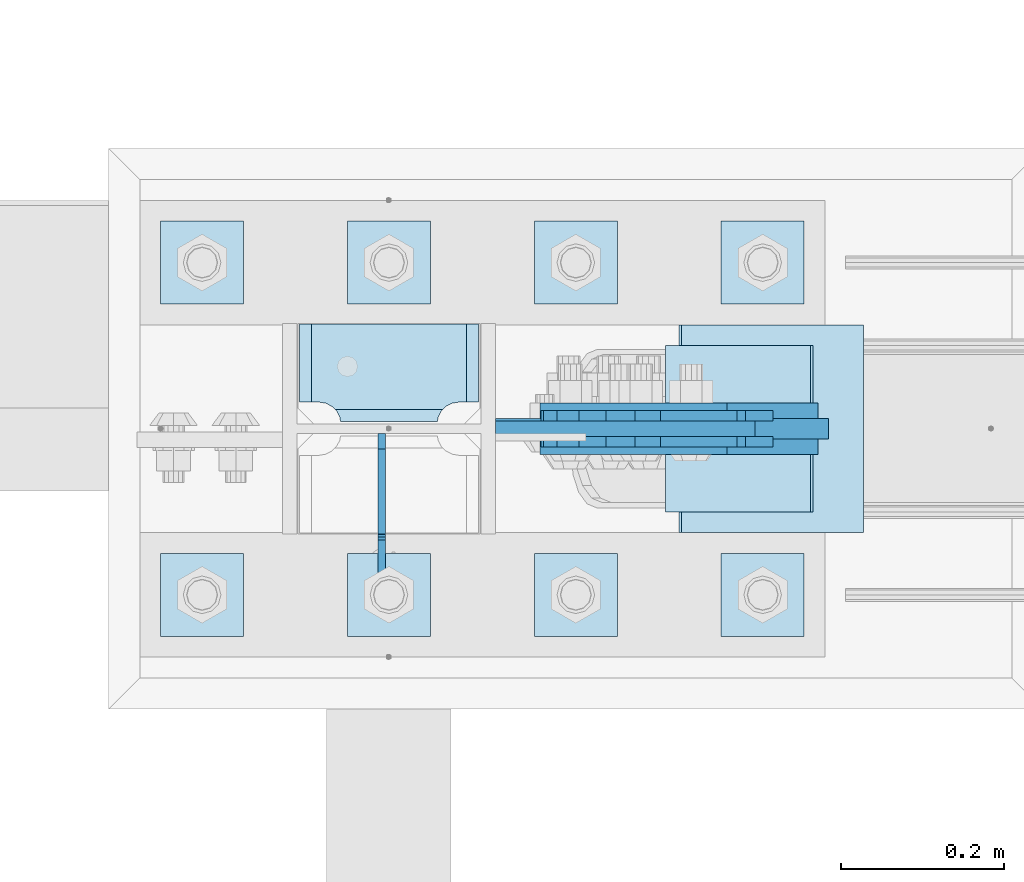
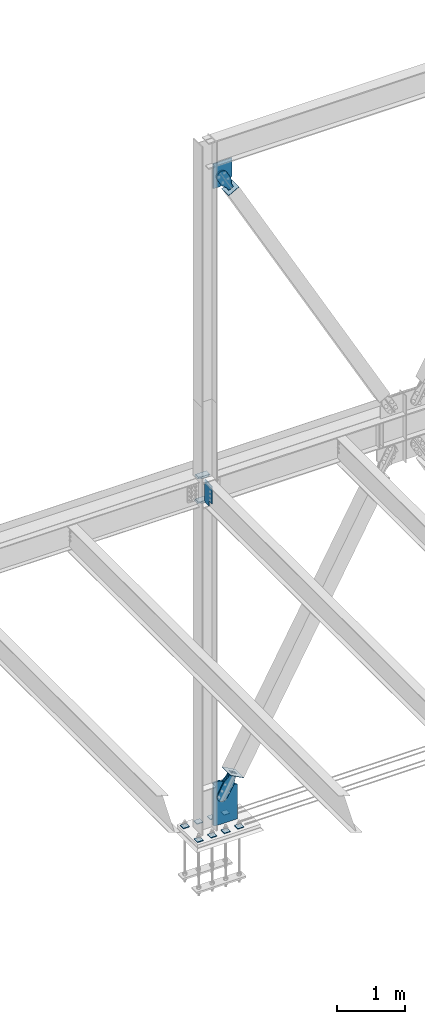
# One storey, part 3527 of 3843: 19 plates, 9 elements without a shape of their own.
"""IFC2X3 building model written with IfcOpenShell, lengths in millimetres."""

from ifc_helpers import new_model, si_unit, frame, origin_with_axes, place, context, subcontext, project, spatial, faceted_brep, material, type_object, element, aggregate, save


model = new_model("IFC2X3")

# Units and contexts
model_context = context("Model", 3, precision=1e-05, world=origin_with_axes())
body_context = subcontext(model_context, "Body", "Model", "MODEL_VIEW")
ifc_project = project(units=[si_unit("LENGTHUNIT", "METRE", prefix="MILLI"), si_unit("AREAUNIT", "SQUARE_METRE"), si_unit("VOLUMEUNIT", "CUBIC_METRE"), si_unit("MASSUNIT", "GRAM", prefix="KILO"), si_unit("TIMEUNIT", "SECOND"), si_unit("PLANEANGLEUNIT", "RADIAN"), si_unit("SOLIDANGLEUNIT", "STERADIAN"), si_unit("THERMODYNAMICTEMPERATUREUNIT", "DEGREE_CELSIUS"), si_unit("LUMINOUSINTENSITYUNIT", "LUMEN")], contexts=[model_context])

# Site, building, storey
site_placement = place(None, origin_with_axes())
site = spatial("IfcSite", under=ifc_project, at=site_placement, CompositionType="ELEMENT")
building_placement = place(site_placement, origin_with_axes())
building = spatial("IfcBuilding", under=site, at=building_placement, Name="Undefined", CompositionType="ELEMENT")
storey_placement = place(building_placement, origin_with_axes())
storey = spatial("IfcBuildingStorey", under=building, at=storey_placement, Name="Undefined", CompositionType="ELEMENT", Elevation=0.0)

# Assembly, plates
assembly_1_placement = place(storey_placement, origin_with_axes())
assembly_1 = element("IfcElementAssembly", 1, at=assembly_1_placement, inside=storey, Name="COLUMN", AssemblyPlace="NOTDEFINED", PredefinedType="RIGID_FRAME")
ifc_material_1 = material(Name="STEEL/A572-50")
plate_type_1 = type_object("IfcPlateType", PredefinedType="NOTDEFINED")
plate_1_placement = place(assembly_1_placement, frame((56043.5125, 104686.89375, 35982.275), z_axis=(-1.0, 0.0, 0.0), x_axis=(0.0, -1.0, 0.0)))
plate_1 = element("IfcPlate", 2, at=plate_1_placement, type_object=plate_type_1, material=ifc_material_1, Name="PLATE", context=body_context, shape_type="Brep", body=[
    faceted_brep([(106.374645952208, 9.27650871939841, 48.8208447555226), (104.398053430486, 12.6999999999971, 46.8442522338009), (104.398053430486, 12.6999999999971, 178.580747766202), (106.374645952208, 9.27650871939841, 176.60415524448), (113.897904100071, -3.75390012199205, 172.770863755024), (119.062750047655, -12.6999999999971, 171.952832520255), (119.062750047655, -12.6999999999971, 53.4721674797474), (113.897904100071, -3.75390012199205, 52.6541362449789), (0.0, 12.6999999999971, 207.584803430516), (0.0, -12.6999999999971, 222.249500047692), (95.2500007629424, -12.6999999999971, 222.249500047692), (95.2500007629424, 12.6999999999971, 207.584803430516), (95.2500007629424, 12.6999999999971, 17.8391965694973), (95.2500007629424, -12.6999999999971, 3.17449995232164), (0.0, -12.6999999999971, 3.17449995232164), (0.0, 12.6999999999971, 17.8391965694973), (95.2500007629424, -12.6999999999971, 198.437500762942), (95.2500007629424, 12.6999999999971, 198.437500762942), (96.5708629920846, -12.6999999999971, 190.097904863011), (96.5708629920846, 12.6999999999971, 190.097904863011), (100.404154481541, -12.6999999999971, 182.574646715148), (100.404154481541, 12.6999999999971, 182.574646715148), (106.374645952208, -12.6999999999971, 176.60415524448), (113.897904100071, -12.6999999999971, 172.770863755024), (113.897904100071, -12.6999999999971, 52.6541362449789), (106.374645952208, -12.6999999999971, 48.8208447555226), (100.404154481541, -12.6999999999971, 42.8503532848626), (100.404154481541, 12.6999999999971, 42.8503532848626), (96.5708629920846, -12.6999999999971, 35.3270951369923), (96.5708629920846, 12.6999999999971, 35.3270951369923), (95.2500007629424, -12.6999999999971, 26.9874992370605), (95.2500007629424, 12.6999999999971, 26.9874992370605)], [[[0, 1, 2, 3, 4, 5, 6, 7]], [[8, 9, 10, 11]], [[12, 13, 14, 15]], [[15, 14, 9, 8]], [[16, 17, 11, 10]], [[16, 18, 19, 17]], [[18, 20, 21, 19]], [[21, 20, 22, 3, 2]], [[22, 23, 4, 3]], [[23, 5, 4]], [[24, 7, 6]], [[24, 25, 0, 7]], [[25, 26, 27, 1, 0]], [[26, 28, 29, 27]], [[28, 30, 31, 29]], [[31, 30, 13, 12]], [[27, 29, 31, 12, 15, 8, 11, 17, 19, 21, 2, 1]], [[13, 30, 28, 26, 25, 24, 6, 5, 23, 22, 20, 18, 16, 10, 9, 14]]]),
])
plate_2_placement = place(assembly_1_placement, frame((56043.5125, 104686.89375, 36423.6), z_axis=(-1.0, 0.0, 0.0), x_axis=(0.0, -1.0, 0.0)))
plate_2 = element("IfcPlate", 3, at=plate_2_placement, type_object=plate_type_1, material=ifc_material_1, Name="PLATE", context=body_context, shape_type="Brep", body=[
    faceted_brep([(106.374645952208, 9.27637393362238, 48.8208447555226), (104.398053430486, 12.6999999999971, 46.8442522338009), (104.398053430486, 12.6999999999971, 178.580747766202), (106.374645952208, 9.27637393362238, 176.60415524448), (113.897904100071, -3.75454792609526, 172.770863755024), (119.062750047655, -12.6999999999971, 171.952832520255), (119.062750047655, -12.6999999999971, 53.4721674797474), (113.897904100071, -3.75454792609526, 52.6541362449789), (0.0, 12.6999999999971, 207.584803430516), (0.0, -12.6999999999971, 222.249500047692), (95.2500007629424, -12.6999999999971, 222.249500047692), (95.2500007629424, 12.6999999999971, 207.584803430516), (95.2500007629424, 12.6999999999971, 17.8391965694973), (95.2500007629424, -12.6999999999971, 3.17449995232164), (0.0, -12.6999999999971, 3.17449995232164), (0.0, 12.6999999999971, 17.8391965694973), (95.2500007629424, -12.6999999999971, 198.437500762942), (95.2500007629424, 12.6999999999971, 198.437500762942), (96.5708629920846, -12.6999999999971, 190.097904863011), (96.5708629920846, 12.6999999999971, 190.097904863011), (100.404154481541, -12.6999999999971, 182.574646715148), (100.404154481541, 12.6999999999971, 182.574646715148), (106.374645952208, -12.6999999999971, 176.60415524448), (113.897904100071, -12.6999999999971, 172.770863755024), (113.897904100071, -12.6999999999971, 52.6541362449789), (106.374645952208, -12.6999999999971, 48.8208447555226), (100.404154481541, -12.6999999999971, 42.8503532848626), (100.404154481541, 12.6999999999971, 42.8503532848626), (96.5708629920846, -12.6999999999971, 35.3270951369923), (96.5708629920846, 12.6999999999971, 35.3270951369923), (95.2500007629424, -12.6999999999971, 26.9874992370605), (95.2500007629424, 12.6999999999971, 26.9874992370605)], [[[0, 1, 2, 3, 4, 5, 6, 7]], [[8, 9, 10, 11]], [[12, 13, 14, 15]], [[15, 14, 9, 8]], [[16, 17, 11, 10]], [[16, 18, 19, 17]], [[18, 20, 21, 19]], [[21, 20, 22, 3, 2]], [[22, 23, 4, 3]], [[23, 5, 4]], [[24, 7, 6]], [[24, 25, 0, 7]], [[25, 26, 27, 1, 0]], [[26, 28, 29, 27]], [[28, 30, 31, 29]], [[31, 30, 13, 12]], [[27, 29, 31, 12, 15, 8, 11, 17, 19, 21, 2, 1]], [[13, 30, 28, 26, 25, 24, 6, 5, 23, 22, 20, 18, 16, 10, 9, 14]]]),
])

# Assembly, plate
assembly_2_placement = place(storey_placement, origin_with_axes())
assembly_2 = element("IfcElementAssembly", 4, at=assembly_2_placement, inside=storey, AssemblyPlace="NOTDEFINED", PredefinedType="RIGID_FRAME")
ifc_material_2 = material(Name="STEEL/A36")
plate_type_2 = type_object("IfcPlateType", PredefinedType="NOTDEFINED")
plate_3_placement = place(assembly_2_placement, frame((56366.8273614966, 104574.975, 41545.1947870551), z_axis=(-0.874070462961121, 0.0, -0.485799161978415), x_axis=(0.485799161978388, 0.0, -0.874070462961137)))
plate_3 = element("IfcPlate", 5, at=plate_3_placement, type_object=plate_type_2, material=ifc_material_2, context=body_context, shape_type="Brep", body=[
    faceted_brep([(0.0, -6.3499999046162, 0.0), (-101.599999999482, -6.35000000000582, -44.6881937832222), (-101.599999999482, 6.35000000000582, -44.6881937832222), (7.27595761418343e-12, 6.3499999046162, 0.0), (-246.684985846376, -6.35000000000582, -44.6881937832586), (-246.684985846376, 6.35000000000582, -44.6881937832586), (-281.313054100305, -6.35000000000582, -37.8002427490646), (-281.313054100305, 6.35000000000582, -37.8002427490646), (-310.669312866783, -6.35000000000582, -18.18501775197), (-310.669312866783, 6.35000000000582, -18.18501775197), (-330.284537863758, -6.35000000000582, 11.1712410146756), (-330.284537863758, 6.35000000000582, 11.1712410146756), (-337.172488897893, -6.35000000000582, 45.7993031645856), (-337.172488897893, 6.35000000000582, 45.7993031645856), (-330.284537863699, -6.35000000000582, 80.4273714186893), (-330.284537863699, 6.35000000000582, 80.4273714186893), (-310.669312866681, -6.35000000000582, 109.783630185331), (-310.669312866681, 6.35000000000582, 109.783630185331), (-281.313054100174, -6.35000000000582, 129.39885518244), (-281.313054100174, 6.35000000000582, 129.39885518244), (-246.684988898312, -6.35000000000582, 136.286806216667), (-246.684988898312, 6.35000000000582, 136.286806216667), (-101.599999999322, -6.35000000000582, 136.286806216689), (-101.599999999322, 6.35000000000582, 136.286806216689), (2.18278728425503e-10, -6.35000000000582, 91.5986124321353), (2.18278728425503e-10, 6.35000000000582, 91.5986124321353), (69.8499999987471, -6.35000000000582, 91.598612432037), (69.8499999987471, 6.35000000000582, 91.598612432037), (69.8499999985434, -6.35000000000582, -8.73114913702011e-11), (69.8499999985434, 6.35000000000582, -8.73114913702011e-11)], [[[0, 1, 2, 3]], [[1, 4, 5, 2]], [[4, 6, 7, 5]], [[6, 8, 9, 7]], [[8, 10, 11, 9]], [[10, 12, 13, 11]], [[12, 14, 15, 13]], [[14, 16, 17, 15]], [[16, 18, 19, 17]], [[18, 20, 21, 19]], [[20, 22, 23, 21]], [[22, 24, 25, 23]], [[24, 26, 27, 25]], [[26, 28, 29, 27]], [[28, 0, 3, 29]], [[5, 7, 9, 11, 13, 15, 17, 19, 21, 23, 25, 27, 29, 3, 2]], [[28, 26, 24, 22, 20, 18, 16, 14, 12, 10, 8, 6, 4, 1, 0]]]),
])
aggregate(assembly_2, [plate_3])

assembly_3_placement = place(storey_placement, origin_with_axes())
assembly_3 = element("IfcElementAssembly", 6, at=assembly_3_placement, inside=storey, AssemblyPlace="NOTDEFINED", PredefinedType="RIGID_FRAME")
plate_4_placement = place(assembly_3_placement, frame((56366.8273614966, 104543.225, 41545.1947870551), z_axis=(-0.874070462961121, 0.0, -0.485799161978415), x_axis=(0.485799161978388, 0.0, -0.874070462961137)))
plate_4 = element("IfcPlate", 7, at=plate_4_placement, type_object=plate_type_2, material=ifc_material_2, context=body_context, shape_type="Brep", body=[
    faceted_brep([(0.0, -6.3499999046162, 0.0), (-101.599999999482, -6.35000000000582, -44.6881937832222), (-101.599999999482, 6.35000000000582, -44.6881937832222), (7.27595761418343e-12, 6.3499999046162, 0.0), (-246.684985846376, -6.35000000000582, -44.6881937832586), (-246.684985846376, 6.35000000000582, -44.6881937832586), (-281.313054100305, -6.35000000000582, -37.8002427490646), (-281.313054100305, 6.35000000000582, -37.8002427490646), (-310.669312866783, -6.35000000000582, -18.18501775197), (-310.669312866783, 6.35000000000582, -18.18501775197), (-330.284537863758, -6.35000000000582, 11.1712410146756), (-330.284537863758, 6.35000000000582, 11.1712410146756), (-337.172488897893, -6.35000000000582, 45.7993031645856), (-337.172488897893, 6.35000000000582, 45.7993031645856), (-330.284537863699, -6.35000000000582, 80.4273714186893), (-330.284537863699, 6.35000000000582, 80.4273714186893), (-310.669312866681, -6.35000000000582, 109.783630185331), (-310.669312866681, 6.35000000000582, 109.783630185331), (-281.313054100174, -6.35000000000582, 129.39885518244), (-281.313054100174, 6.35000000000582, 129.39885518244), (-246.684988898312, -6.35000000000582, 136.286806216667), (-246.684988898312, 6.35000000000582, 136.286806216667), (-101.599999999322, -6.35000000000582, 136.286806216689), (-101.599999999322, 6.35000000000582, 136.286806216689), (2.18278728425503e-10, -6.35000000000582, 91.5986124321353), (2.18278728425503e-10, 6.35000000000582, 91.5986124321353), (69.8499999987471, -6.35000000000582, 91.598612432037), (69.8499999987471, 6.35000000000582, 91.598612432037), (69.8499999985434, -6.35000000000582, -8.73114913702011e-11), (69.8499999985434, 6.35000000000582, -8.73114913702011e-11)], [[[0, 1, 2, 3]], [[1, 4, 5, 2]], [[4, 6, 7, 5]], [[6, 8, 9, 7]], [[8, 10, 11, 9]], [[10, 12, 13, 11]], [[12, 14, 15, 13]], [[14, 16, 17, 15]], [[16, 18, 19, 17]], [[18, 20, 21, 19]], [[20, 22, 23, 21]], [[22, 24, 25, 23]], [[24, 26, 27, 25]], [[26, 28, 29, 27]], [[28, 0, 3, 29]], [[5, 7, 9, 11, 13, 15, 17, 19, 21, 23, 25, 27, 29, 3, 2]], [[28, 26, 24, 22, 20, 18, 16, 14, 12, 10, 8, 6, 4, 1, 0]]]),
])
aggregate(assembly_3, [plate_4])

assembly_4_placement = place(storey_placement, origin_with_axes())
assembly_4 = element("IfcElementAssembly", 8, at=assembly_4_placement, inside=storey, Name="Plate", AssemblyPlace="NOTDEFINED", PredefinedType="RIGID_FRAME")
plate_type_3 = type_object("IfcPlateType", PredefinedType="NOTDEFINED")
plate_5_placement = place(assembly_4_placement, frame((56270.3806407939, 104660.7, 41415.3096795061), z_axis=(0.874070462961137, 0.0, 0.485799161978387), x_axis=(0.0, -1.0, 0.0)))
plate_5 = element("IfcPlate", 9, at=plate_5_placement, type_object=plate_type_3, material=ifc_material_2, Name="Plate", context=body_context, shape_type="Brep", body=[
    faceted_brep([(0.0, -3.17499999999927, 0.0), (0.0, -3.17500000043947, 203.200000001736), (0.0, 3.1749999995518, 203.200000001743), (0.0, 3.17499999999927, 0.0), (203.200000000012, -3.17500000043947, 203.200000001736), (203.200000000012, 3.1749999995518, 203.200000001743), (203.199996948242, -3.17499999999927, 0.0), (203.199996948242, 3.17499999999927, 0.0)], [[[0, 1, 2, 3]], [[1, 4, 5, 2]], [[4, 6, 7, 5]], [[6, 0, 3, 7]], [[5, 7, 3, 2]], [[6, 4, 1, 0]]]),
])
aggregate(assembly_4, [plate_5])

assembly_5_placement = place(storey_placement, origin_with_axes())
assembly_5 = element("IfcElementAssembly", 10, at=assembly_5_placement, inside=storey, Name="CB", AssemblyPlace="NOTDEFINED", PredefinedType="RIGID_FRAME")
plate_type_4 = type_object("IfcPlateType", PredefinedType="NOTDEFINED")
plate_6_placement = place(assembly_5_placement, frame((56378.7321866221, 104559.1, 42002.075), z_axis=(0.0, 0.0, -1.0), x_axis=(-1.0, 0.0, 0.0)))
plate_6 = element("IfcPlate", 11, at=plate_6_placement, type_object=plate_type_4, material=ifc_material_1, Name="CB", context=body_context, shape_type="Brep", body=[
    faceted_brep([(0.0, -9.52500000000146, 0.0), (0.0, -9.52499999999418, 334.025869885023), (0.0, 9.52499999999418, 334.025869885023), (0.0, 9.52500000000146, 0.0), (202.587681399702, -9.52499999999418, 446.621970928063), (202.587681399702, 9.52499999999418, 446.621970928063), (317.757186315437, -9.52499999999418, 446.621970928063), (317.757186315437, 9.52499999999418, 446.621970928063), (317.757186315437, -9.52499999999418, 0.0), (317.757186315437, 9.52499999999418, 0.0)], [[[0, 1, 2, 3]], [[1, 4, 5, 2]], [[4, 6, 7, 5]], [[6, 8, 9, 7]], [[8, 0, 3, 9]], [[5, 7, 9, 3, 2]], [[8, 6, 4, 1, 0]]]),
])
aggregate(assembly_5, [plate_6])

# Assembly, plates
assembly_6_placement = place(storey_placement, origin_with_axes())
assembly_6 = element("IfcElementAssembly", 12, at=assembly_6_placement, inside=storey, Name="TEMPLATE", AssemblyPlace="NOTDEFINED", PredefinedType="RIGID_FRAME")
plate_type_5 = type_object("IfcPlateType", PredefinedType="NOTDEFINED")
plate_7_placement = place(assembly_6_placement, frame((56337.2, 104406.7, 30130.75), z_axis=(0.0, -1.0, 0.0), x_axis=(1.0, 0.0, 0.0)))
plate_7 = element("IfcPlate", 13, at=plate_7_placement, type_object=plate_type_5, material=ifc_material_1, Name="Washer Plate", context=body_context, shape_type="Brep", body=[
    faceted_brep([(0.0, -6.3499999046162, 0.0), (-1.67347025126219e-10, -6.35000000000582, 101.600000000151), (-1.67347025126219e-10, 6.35000000000582, 101.600000000151), (7.27595761418343e-12, 6.3499999046162, 0.0), (101.599998474121, -6.34999999999854, 101.599998474121), (101.599998474121, 6.34999999999854, 101.599998474121), (101.6, -6.34999999999854, 0.0), (101.6, 6.34999999999854, 0.0)], [[[0, 1, 2, 3]], [[1, 4, 5, 2]], [[4, 6, 7, 5]], [[6, 0, 3, 7]], [[5, 7, 3, 2]], [[6, 4, 1, 0]]]),
])
plate_8_placement = place(assembly_6_placement, frame((56337.2, 104813.1, 30130.75), z_axis=(0.0, -1.0, 0.0), x_axis=(1.0, 0.0, 0.0)))
plate_8 = element("IfcPlate", 14, at=plate_8_placement, type_object=plate_type_5, material=ifc_material_1, Name="Washer Plate", context=body_context, shape_type="Brep", body=[
    faceted_brep([(0.0, -6.3499999046162, 0.0), (-1.67347025126219e-10, -6.35000000000582, 101.600000000151), (-1.67347025126219e-10, 6.35000000000582, 101.600000000151), (7.27595761418343e-12, 6.3499999046162, 0.0), (101.599998474121, -6.34999999999854, 101.599998474121), (101.599998474121, 6.34999999999854, 101.599998474121), (101.6, -6.34999999999854, 0.0), (101.6, 6.34999999999854, 0.0)], [[[0, 1, 2, 3]], [[1, 4, 5, 2]], [[4, 6, 7, 5]], [[6, 0, 3, 7]], [[5, 7, 3, 2]], [[6, 4, 1, 0]]]),
])
plate_9_placement = place(assembly_6_placement, frame((56108.6, 104406.7, 30130.75), z_axis=(0.0, -1.0, 0.0), x_axis=(1.0, 0.0, 0.0)))
plate_9 = element("IfcPlate", 15, at=plate_9_placement, type_object=plate_type_5, material=ifc_material_1, Name="Washer Plate", context=body_context, shape_type="Brep", body=[
    faceted_brep([(0.0, -6.3499999046162, 0.0), (-1.67347025126219e-10, -6.35000000000582, 101.600000000151), (-1.67347025126219e-10, 6.35000000000582, 101.600000000151), (7.27595761418343e-12, 6.3499999046162, 0.0), (101.599998474121, -6.34999999999854, 101.599998474121), (101.599998474121, 6.34999999999854, 101.599998474121), (101.6, -6.34999999999854, 0.0), (101.6, 6.34999999999854, 0.0)], [[[0, 1, 2, 3]], [[1, 4, 5, 2]], [[4, 6, 7, 5]], [[6, 0, 3, 7]], [[5, 7, 3, 2]], [[6, 4, 1, 0]]]),
])
plate_10_placement = place(assembly_6_placement, frame((56108.6, 104813.1, 30130.75), z_axis=(0.0, -1.0, 0.0), x_axis=(1.0, 0.0, 0.0)))
plate_10 = element("IfcPlate", 16, at=plate_10_placement, type_object=plate_type_5, material=ifc_material_1, Name="Washer Plate", context=body_context, shape_type="Brep", body=[
    faceted_brep([(0.0, -6.3499999046162, 0.0), (-1.67347025126219e-10, -6.35000000000582, 101.600000000151), (-1.67347025126219e-10, 6.35000000000582, 101.600000000151), (7.27595761418343e-12, 6.3499999046162, 0.0), (101.599998474121, -6.34999999999854, 101.599998474121), (101.599998474121, 6.34999999999854, 101.599998474121), (101.6, -6.34999999999854, 0.0), (101.6, 6.34999999999854, 0.0)], [[[0, 1, 2, 3]], [[1, 4, 5, 2]], [[4, 6, 7, 5]], [[6, 0, 3, 7]], [[5, 7, 3, 2]], [[6, 4, 1, 0]]]),
])
plate_11_placement = place(assembly_6_placement, frame((55880.0, 104406.7, 30130.75), z_axis=(0.0, -1.0, 0.0), x_axis=(1.0, 0.0, 0.0)))
plate_11 = element("IfcPlate", 17, at=plate_11_placement, type_object=plate_type_5, material=ifc_material_1, Name="Washer Plate", context=body_context, shape_type="Brep", body=[
    faceted_brep([(0.0, -6.3499999046162, 0.0), (-1.67347025126219e-10, -6.35000000000582, 101.600000000151), (-1.67347025126219e-10, 6.35000000000582, 101.600000000151), (7.27595761418343e-12, 6.3499999046162, 0.0), (101.599998474121, -6.34999999999854, 101.599998474121), (101.599998474121, 6.34999999999854, 101.599998474121), (101.6, -6.34999999999854, 0.0), (101.6, 6.34999999999854, 0.0)], [[[0, 1, 2, 3]], [[1, 4, 5, 2]], [[4, 6, 7, 5]], [[6, 0, 3, 7]], [[5, 7, 3, 2]], [[6, 4, 1, 0]]]),
])
plate_12_placement = place(assembly_6_placement, frame((55880.0, 104813.1, 30130.75), z_axis=(0.0, -1.0, 0.0), x_axis=(1.0, 0.0, 0.0)))
plate_12 = element("IfcPlate", 18, at=plate_12_placement, type_object=plate_type_5, material=ifc_material_1, Name="Washer Plate", context=body_context, shape_type="Brep", body=[
    faceted_brep([(0.0, -6.3499999046162, 0.0), (-1.67347025126219e-10, -6.35000000000582, 101.600000000151), (-1.67347025126219e-10, 6.35000000000582, 101.600000000151), (7.27595761418343e-12, 6.3499999046162, 0.0), (101.599998474121, -6.34999999999854, 101.599998474121), (101.599998474121, 6.34999999999854, 101.599998474121), (101.6, -6.34999999999854, 0.0), (101.6, 6.34999999999854, 0.0)], [[[0, 1, 2, 3]], [[1, 4, 5, 2]], [[4, 6, 7, 5]], [[6, 0, 3, 7]], [[5, 7, 3, 2]], [[6, 4, 1, 0]]]),
])
plate_13_placement = place(assembly_6_placement, frame((55651.4, 104406.7, 30130.75), z_axis=(0.0, -1.0, 0.0), x_axis=(1.0, 0.0, 0.0)))
plate_13 = element("IfcPlate", 19, at=plate_13_placement, type_object=plate_type_5, material=ifc_material_1, Name="Washer Plate", context=body_context, shape_type="Brep", body=[
    faceted_brep([(0.0, -6.3499999046162, 0.0), (-1.67347025126219e-10, -6.35000000000582, 101.600000000151), (-1.67347025126219e-10, 6.35000000000582, 101.600000000151), (7.27595761418343e-12, 6.3499999046162, 0.0), (101.599998474121, -6.34999999999854, 101.599998474121), (101.599998474121, 6.34999999999854, 101.599998474121), (101.6, -6.34999999999854, 0.0), (101.6, 6.34999999999854, 0.0)], [[[0, 1, 2, 3]], [[1, 4, 5, 2]], [[4, 6, 7, 5]], [[6, 0, 3, 7]], [[5, 7, 3, 2]], [[6, 4, 1, 0]]]),
])
plate_14_placement = place(assembly_6_placement, frame((55651.4, 104813.1, 30130.75), z_axis=(0.0, -1.0, 0.0), x_axis=(1.0, 0.0, 0.0)))
plate_14 = element("IfcPlate", 20, at=plate_14_placement, type_object=plate_type_5, material=ifc_material_1, Name="Washer Plate", context=body_context, shape_type="Brep", body=[
    faceted_brep([(0.0, -6.3499999046162, 0.0), (-1.67347025126219e-10, -6.35000000000582, 101.600000000151), (-1.67347025126219e-10, 6.35000000000582, 101.600000000151), (7.27595761418343e-12, 6.3499999046162, 0.0), (101.599998474121, -6.34999999999854, 101.599998474121), (101.599998474121, 6.34999999999854, 101.599998474121), (101.6, -6.34999999999854, 0.0), (101.6, 6.34999999999854, 0.0)], [[[0, 1, 2, 3]], [[1, 4, 5, 2]], [[4, 6, 7, 5]], [[6, 0, 3, 7]], [[5, 7, 3, 2]], [[6, 4, 1, 0]]]),
])
aggregate(assembly_6, [plate_7, plate_8, plate_9, plate_10, plate_11, plate_12, plate_13, plate_14])

# Assembly, plate
assembly_7_placement = place(storey_placement, origin_with_axes())
assembly_7 = element("IfcElementAssembly", 21, at=assembly_7_placement, inside=storey, AssemblyPlace="NOTDEFINED", PredefinedType="RIGID_FRAME")
plate_type_6 = type_object("IfcPlateType", PredefinedType="NOTDEFINED")
plate_15_placement = place(assembly_7_placement, frame((56421.9177728887, 104581.325, 30883.2808557797), z_axis=(-0.875631045218185, 0.0, 0.482980613120351), x_axis=(0.482980613120339, 0.0, 0.875631045218191)))
plate_15 = element("IfcPlate", 22, at=plate_15_placement, type_object=plate_type_6, material=ifc_material_2, context=body_context, shape_type="Brep", body=[
    faceted_brep([(0.0, -9.52500000000146, 0.0), (-101.599999996755, -9.52499999999418, -33.324272213511), (-101.599999996755, 9.52499999999418, -33.324272213511), (0.0, 9.52500000000146, 0.0), (-320.279297653902, -9.52499999999418, -33.3242722122595), (-320.279297653902, 9.52499999999418, -33.3242722122595), (-357.337405119242, -9.52499999999418, -25.9529563255783), (-357.337405119242, 9.52499999999418, -25.9529563255783), (-388.753751655597, -9.52499999999418, -4.96122468852991), (-388.753751655597, 9.52499999999418, -4.96122468852991), (-409.745483292782, -9.52499999999418, 26.4551218477136), (-409.745483292782, 9.52499999999418, 26.4551218477136), (-417.116799179586, -9.52499999999418, 63.5132262653569), (-417.116799179586, 9.52499999999418, 63.5132262653569), (-409.745483293211, -9.52499999999418, 100.57133373119), (-409.745483293211, 9.52499999999418, 100.57133373119), (-388.753751656006, -9.52499999999418, 131.987680267928), (-388.753751656006, 9.52499999999418, 131.987680267928), (-357.337405119271, -9.52499999999418, 152.97941190518), (-357.337405119271, 9.52499999999418, 152.97941190518), (-320.279299183247, -9.52499999999418, 160.350727791658), (-320.279299183247, 9.52499999999418, 160.350727791658), (-101.599999998418, -9.52499999999418, 160.350727790414), (-101.599999998418, 9.52499999999418, 160.350727790414), (-1.04046193882823e-09, -9.52499999999418, 127.02645557576), (-1.04046193882823e-09, 9.52499999999418, 127.02645557576), (69.8499999968899, -9.52499999999418, 127.026455575353), (69.8499999968899, 9.52499999999418, 127.026455575353), (69.8499999979995, -9.52499999999418, -4.00177668780088e-10), (69.8499999979995, 9.52499999999418, -4.00177668780088e-10)], [[[0, 1, 2, 3]], [[1, 4, 5, 2]], [[4, 6, 7, 5]], [[6, 8, 9, 7]], [[8, 10, 11, 9]], [[10, 12, 13, 11]], [[12, 14, 15, 13]], [[14, 16, 17, 15]], [[16, 18, 19, 17]], [[18, 20, 21, 19]], [[20, 22, 23, 21]], [[22, 24, 25, 23]], [[24, 26, 27, 25]], [[26, 28, 29, 27]], [[28, 0, 3, 29]], [[5, 7, 9, 11, 13, 15, 17, 19, 21, 23, 25, 27, 29, 3, 2]], [[28, 26, 24, 22, 20, 18, 16, 14, 12, 10, 8, 6, 4, 1, 0]]]),
])
aggregate(assembly_7, [plate_15])

assembly_8_placement = place(storey_placement, origin_with_axes())
assembly_8 = element("IfcElementAssembly", 23, at=assembly_8_placement, inside=storey, AssemblyPlace="NOTDEFINED", PredefinedType="RIGID_FRAME")
plate_16_placement = place(assembly_8_placement, frame((56421.9177728887, 104536.875, 30883.2808557797), z_axis=(-0.875631045218185, 0.0, 0.482980613120351), x_axis=(0.482980613120339, 0.0, 0.875631045218191)))
plate_16 = element("IfcPlate", 24, at=plate_16_placement, type_object=plate_type_6, material=ifc_material_2, context=body_context, shape_type="Brep", body=[
    faceted_brep([(0.0, -9.52500000000146, 0.0), (-101.599999996755, -9.52499999999418, -33.324272213511), (-101.599999996755, 9.52499999999418, -33.324272213511), (0.0, 9.52500000000146, 0.0), (-320.279297653902, -9.52499999999418, -33.3242722122595), (-320.279297653902, 9.52499999999418, -33.3242722122595), (-357.337405119242, -9.52499999999418, -25.9529563255783), (-357.337405119242, 9.52499999999418, -25.9529563255783), (-388.753751655597, -9.52499999999418, -4.96122468852991), (-388.753751655597, 9.52499999999418, -4.96122468852991), (-409.745483292782, -9.52499999999418, 26.4551218477136), (-409.745483292782, 9.52499999999418, 26.4551218477136), (-417.116799179586, -9.52499999999418, 63.5132262653569), (-417.116799179586, 9.52499999999418, 63.5132262653569), (-409.745483293211, -9.52499999999418, 100.57133373119), (-409.745483293211, 9.52499999999418, 100.57133373119), (-388.753751656006, -9.52499999999418, 131.987680267928), (-388.753751656006, 9.52499999999418, 131.987680267928), (-357.337405119271, -9.52499999999418, 152.97941190518), (-357.337405119271, 9.52499999999418, 152.97941190518), (-320.279299183247, -9.52499999999418, 160.350727791658), (-320.279299183247, 9.52499999999418, 160.350727791658), (-101.599999998418, -9.52499999999418, 160.350727790414), (-101.599999998418, 9.52499999999418, 160.350727790414), (-1.04046193882823e-09, -9.52499999999418, 127.02645557576), (-1.04046193882823e-09, 9.52499999999418, 127.02645557576), (69.8499999968899, -9.52499999999418, 127.026455575353), (69.8499999968899, 9.52499999999418, 127.026455575353), (69.8499999979995, -9.52499999999418, -4.00177668780088e-10), (69.8499999979995, 9.52499999999418, -4.00177668780088e-10)], [[[0, 1, 2, 3]], [[1, 4, 5, 2]], [[4, 6, 7, 5]], [[6, 8, 9, 7]], [[8, 10, 11, 9]], [[10, 12, 13, 11]], [[12, 14, 15, 13]], [[14, 16, 17, 15]], [[16, 18, 19, 17]], [[18, 20, 21, 19]], [[20, 22, 23, 21]], [[22, 24, 25, 23]], [[24, 26, 27, 25]], [[26, 28, 29, 27]], [[28, 0, 3, 29]], [[5, 7, 9, 11, 13, 15, 17, 19, 21, 23, 25, 27, 29, 3, 2]], [[28, 26, 24, 22, 20, 18, 16, 14, 12, 10, 8, 6, 4, 1, 0]]]),
])
aggregate(assembly_8, [plate_16])

assembly_9_placement = place(storey_placement, origin_with_axes())
assembly_9 = element("IfcElementAssembly", 25, at=assembly_9_placement, inside=storey, Name="Plate", AssemblyPlace="NOTDEFINED", PredefinedType="RIGID_FRAME")
plate_type_7 = type_object("IfcPlateType", PredefinedType="NOTDEFINED")
plate_17_placement = place(assembly_9_placement, frame((56509.7114935735, 104432.1, 30911.0006757801), z_axis=(-0.875631045218185, 0.0, 0.482980613120351), x_axis=(0.0, 1.0, 0.0)))
plate_17 = element("IfcPlate", 26, at=plate_17_placement, type_object=plate_type_7, material=ifc_material_2, Name="Plate", context=body_context, shape_type="Brep", body=[
    faceted_brep([(0.0, -3.17499999999927, 0.0), (0.0, -3.17499999965185, 254.000000005151), (0.0, 3.17500000035216, 254.000000005166), (0.0, 3.17499999999927, 0.0), (254.0, -3.17499999965185, 254.000000005151), (254.0, 3.17500000035216, 254.000000005166), (254.0, -3.17500000000291, 0.0), (254.0, 3.17499999999927, 1.45519152283669e-11)], [[[0, 1, 2, 3]], [[1, 4, 5, 2]], [[4, 6, 7, 5]], [[6, 0, 3, 7]], [[5, 7, 3, 2]], [[6, 4, 1, 0]]]),
])
aggregate(assembly_9, [plate_17])

# Plate
plate_type_8 = type_object("IfcPlateType", PredefinedType="NOTDEFINED")
plate_18_placement = place(assembly_1_placement, frame((56060.975, 104559.1, 30124.4), z_axis=(0.0, 0.0, 1.0), x_axis=(1.0, 0.0, 0.0)))
plate_18 = element("IfcPlate", 27, at=plate_18_placement, type_object=plate_type_8, material=ifc_material_1, Name="CB", context=body_context, shape_type="Brep", body=[
    faceted_brep([(0.0, -12.6999999999971, 19.0499992370605), (0.0, -12.6999999999971, 784.166157121883), (0.0, 12.6999999999971, 784.166157121883), (0.0, 12.6999999999971, 19.0499992370605), (104.740781570647, -12.6999999999971, 784.166157121883), (104.740781570647, 12.6999999999971, 784.166157121883), (407.77479554453, -12.6999999999971, 617.018641436258), (407.77479554453, 12.6999999999971, 617.018641436258), (407.77479554453, -12.6999999999971, 0.0), (407.77479554453, 12.6999999999971, 0.0), (19.0500015258731, -12.6999999999971, -6.33008312433958e-10), (19.0500015258731, 12.6999999999971, 0.0)], [[[0, 1, 2, 3]], [[1, 4, 5, 2]], [[4, 6, 7, 5]], [[6, 8, 9, 7]], [[8, 10, 11, 9]], [[10, 0, 3, 11]], [[5, 7, 9, 11, 3, 2]], [[10, 8, 6, 4, 1, 0]]]),
])

plate_type_9 = type_object("IfcPlateType", PredefinedType="NOTDEFINED")
plate_19_placement = place(assembly_1_placement, frame((55922.0682500839, 104553.54375, 36014.025), z_axis=(0.0, -0.707106781186682, 0.707106781186413), x_axis=(0.0, -0.707106781186548, -0.707106781186548)))
plate_19 = element("IfcPlate", 28, at=plate_19_placement, type_object=plate_type_9, material=ifc_material_1, Name="PLATE", context=body_context, shape_type="Brep", body=[
    faceted_brep([(0.0, -4.76249999999709, 0.0), (-267.162619600509, -4.76249999999709, 267.162619600524), (-267.162619600509, 4.76249999999709, 267.162619600524), (0.0, 4.76249999999709, 0.0), (-267.162619600218, -4.76249999999709, 294.103387963914), (-267.162619600218, 4.76249999999709, 294.103387963914), (-193.636772472979, -4.76249999999709, 367.629234821448), (-193.636772472979, 4.76249999999709, 367.629234821448), (-189.516596004818, -4.76249999999709, 364.876220920996), (-189.516596004818, 4.76249999999709, 364.876220920996), (-184.656516486764, -4.76249999999709, 363.909490998427), (-184.656516486764, 4.76249999999709, 363.909490998427), (-179.796436968696, -4.76249999999709, 364.87622092104), (-179.796436968696, 4.76249999999709, 364.87622092104), (-175.676260500521, -4.76249999999709, 367.629234821536), (-175.676260500521, 4.76249999999709, 367.629234821536), (-121.794723638319, -4.76249999999709, 421.510771683737), (-121.794723638319, 4.76249999999709, 421.510771683737), (102.711679387328, -4.76249999999709, 197.004368658098), (102.711679387328, 4.76249999999709, 197.004368658098), (54.4428032751748, -4.76249999999709, 148.735492545959), (54.4428032751748, 4.76249999999709, 148.735492545959), (49.9691554542806, -4.76249999999709, 142.040205437093), (49.9691554542806, 4.76249999999709, 142.040205437093), (48.3982192483527, -4.76249999999709, 134.142575809667), (48.3982192483527, 4.76249999999709, 134.142575809667), (49.9691554541932, -4.76249999999709, 126.244946182254), (49.9691554541932, 4.76249999999709, 126.244946182254), (54.4428032750293, -4.76249999999709, 119.54965907344), (54.4428032750293, 4.76249999999709, 119.54965907344), (100.466615355763, -4.76249999999709, 73.5258469927066), (100.466615355763, 4.76249999999709, 73.5258469927066), (26.9407683631998, -4.76249999999709, 1.30967237055302e-10), (26.9407683631998, 4.76249999999709, 1.30967237055302e-10)], [[[0, 1, 2, 3]], [[1, 4, 5, 2]], [[4, 6, 7, 5]], [[6, 8, 9, 7]], [[8, 10, 11, 9]], [[10, 12, 13, 11]], [[12, 14, 15, 13]], [[14, 16, 17, 15]], [[16, 18, 19, 17]], [[18, 20, 21, 19]], [[20, 22, 23, 21]], [[22, 24, 25, 23]], [[24, 26, 27, 25]], [[26, 28, 29, 27]], [[28, 30, 31, 29]], [[30, 32, 33, 31]], [[32, 0, 3, 33]], [[5, 7, 9, 11, 13, 15, 17, 19, 21, 23, 25, 27, 29, 31, 33, 3, 2]], [[32, 30, 28, 26, 24, 22, 20, 18, 16, 14, 12, 10, 8, 6, 4, 1, 0]]]),
])

aggregate(assembly_1, [plate_18, plate_1, plate_2, plate_19])

save(model, "model.ifc")
